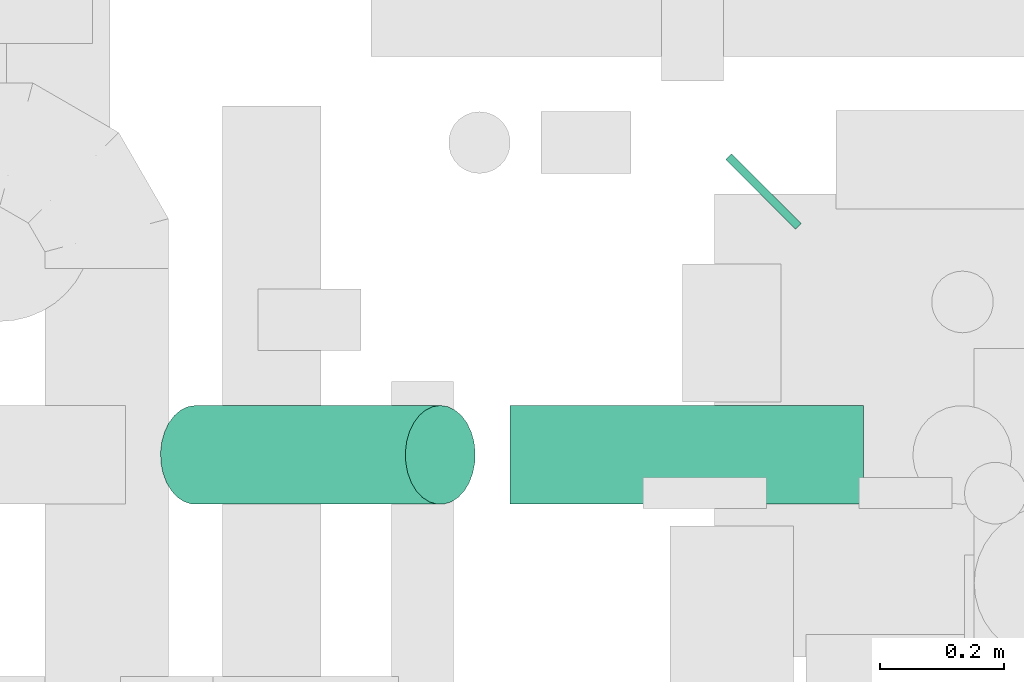
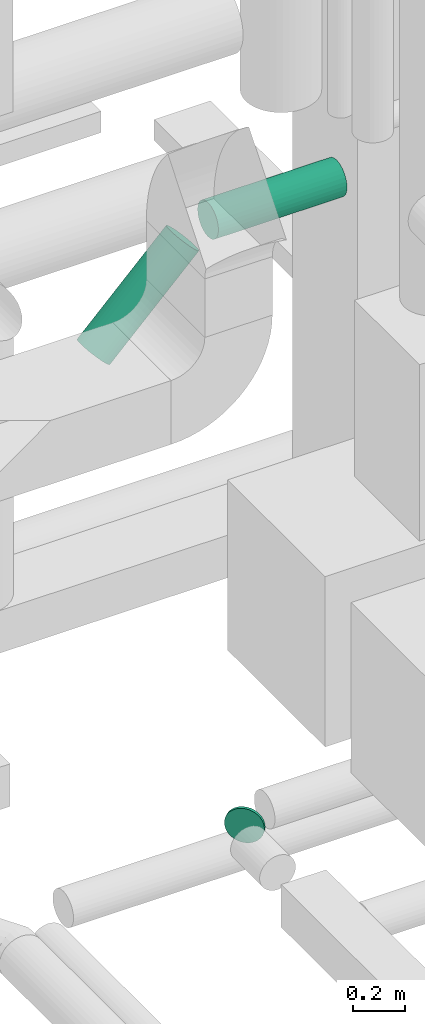
# One storey, part 244 of 337: 3 flow segments.
"""IFC2X3 building model written with IfcOpenShell, lengths in millimetres."""

from ifc_helpers import new_model, entity, si_unit, converted_unit, derived_unit, direction, frame, origin, origin_2d_with_axis, place, context, subcontext, project, spatial, circle, extrude, type_object, element, save


model = new_model("IFC2X3")

# Units and contexts
model_context = context("Model", 3, precision=0.01, world=origin(), true_north=direction((6.12303176911189e-17, 1.0)))
body_context = subcontext(model_context, "Body", "Model", "MODEL_VIEW")
ifc_project = project(units=[si_unit("LENGTHUNIT", "METRE", prefix="MILLI"), si_unit("AREAUNIT", "SQUARE_METRE"), si_unit("VOLUMEUNIT", "CUBIC_METRE"), converted_unit("PLANEANGLEUNIT", "DEGREE", entity("IfcRatioMeasure", 0.0174532925199433), si_unit("PLANEANGLEUNIT", "RADIAN"), dimensions=[0, 0, 0, 0, 0, 0, 0]), si_unit("MASSUNIT", "GRAM", prefix="KILO"), derived_unit("MASSDENSITYUNIT", [(si_unit("MASSUNIT", "GRAM", prefix="KILO"), 1), (si_unit("LENGTHUNIT", "METRE"), -3)]), derived_unit("MOMENTOFINERTIAUNIT", [(si_unit("LENGTHUNIT", "METRE"), 4)]), si_unit("TIMEUNIT", "SECOND"), si_unit("FREQUENCYUNIT", "HERTZ"), si_unit("THERMODYNAMICTEMPERATUREUNIT", "DEGREE_CELSIUS"), derived_unit("THERMALTRANSMITTANCEUNIT", [(si_unit("MASSUNIT", "GRAM", prefix="KILO"), 1), (si_unit("THERMODYNAMICTEMPERATUREUNIT", "KELVIN"), -1), (si_unit("TIMEUNIT", "SECOND"), -3)]), derived_unit("VOLUMETRICFLOWRATEUNIT", [(si_unit("LENGTHUNIT", "METRE"), 3), (si_unit("TIMEUNIT", "SECOND"), -1)]), derived_unit("MASSFLOWRATEUNIT", [(si_unit("MASSUNIT", "GRAM", prefix="KILO"), 1), (si_unit("TIMEUNIT", "SECOND"), -1)]), derived_unit("ROTATIONALFREQUENCYUNIT", [(si_unit("TIMEUNIT", "SECOND"), -1)]), si_unit("ELECTRICCURRENTUNIT", "AMPERE"), si_unit("ELECTRICVOLTAGEUNIT", "VOLT"), si_unit("POWERUNIT", "WATT"), si_unit("FORCEUNIT", "NEWTON", prefix="KILO"), si_unit("ILLUMINANCEUNIT", "LUX"), si_unit("LUMINOUSFLUXUNIT", "LUMEN"), si_unit("LUMINOUSINTENSITYUNIT", "CANDELA"), derived_unit("USERDEFINED", [(si_unit("MASSUNIT", "GRAM", prefix="KILO"), -1), (si_unit("LENGTHUNIT", "METRE"), -2), (si_unit("TIMEUNIT", "SECOND"), 3), (si_unit("LUMINOUSFLUXUNIT", "LUMEN"), 1)]), derived_unit("LINEARVELOCITYUNIT", [(si_unit("LENGTHUNIT", "METRE"), 1), (si_unit("TIMEUNIT", "SECOND"), -1)]), si_unit("PRESSUREUNIT", "PASCAL"), derived_unit("USERDEFINED", [(si_unit("LENGTHUNIT", "METRE"), -2), (si_unit("MASSUNIT", "GRAM", prefix="KILO"), 1), (si_unit("TIMEUNIT", "SECOND"), -2)]), derived_unit("LINEARFORCEUNIT", [(si_unit("MASSUNIT", "GRAM", prefix="KILO"), 1), (si_unit("LENGTHUNIT", "METRE"), 1), (si_unit("TIMEUNIT", "SECOND"), -2), (si_unit("LENGTHUNIT", "METRE"), -1)]), derived_unit("PLANARFORCEUNIT", [(si_unit("MASSUNIT", "GRAM", prefix="KILO"), 1), (si_unit("LENGTHUNIT", "METRE"), 1), (si_unit("TIMEUNIT", "SECOND"), -2), (si_unit("LENGTHUNIT", "METRE"), -2)])], contexts=[model_context])

# Site, building, storey
site_placement = place(None, origin())
site = spatial("IfcSite", under=ifc_project, at=site_placement, CompositionType="ELEMENT")
building_placement = place(site_placement, origin())
building = spatial("IfcBuilding", under=site, at=building_placement, CompositionType="ELEMENT")
storey_placement = place(building_placement, origin())
storey = spatial("IfcBuildingStorey", under=building, at=storey_placement, CompositionType="ELEMENT", Elevation=0.0)

# Flow segments
duct_segment_type = type_object("IfcDuctSegmentType", PredefinedType="NOTDEFINED")
flow_segment_1_placement = place(storey_placement, frame((55066.07, 12222.03, 27468.4)))
element("IfcFlowSegment", 1, at=flow_segment_1_placement, inside=storey, type_object=duct_segment_type, context=body_context, shape_type="SweptSolid", body=[
    extrude(circle(Radius=80.0, at=origin_2d_with_axis()), frame((58.16, 58.16, 81.6), z_axis=(0.707106781186632, 0.707106781186464, 0.0), x_axis=(0.707106781186464, -0.707106781186632, 0.0)), (0.0, 0.0, 1.0), 12.8932188133778),
])
flow_segment_2_placement = place(storey_placement, frame((54718.92, 11776.4, 30713.4)))
element("IfcFlowSegment", 2, at=flow_segment_2_placement, inside=storey, type_object=duct_segment_type, context=body_context, shape_type="SweptSolid", body=[
    extrude(circle(Radius=80.0, at=origin_2d_with_axis()), frame((0.0, 81.6, 81.6), z_axis=(1.0, 0.0, 0.0), x_axis=(0.0, 1.0, 0.0)), (0.0, 0.0, 1.0), 571.785442413998),
])
flow_segment_3_placement = place(storey_placement, frame((54151.35, 11776.4, 30293.7)))
element("IfcFlowSegment", 3, at=flow_segment_3_placement, inside=storey, type_object=duct_segment_type, context=body_context, shape_type="SweptSolid", body=[
    extrude(circle(Radius=80.0, at=origin_2d_with_axis()), frame((58.16, 81.6, 58.16), z_axis=(0.707106781186551, 0.0, 0.707106781186544), x_axis=(0.0, 1.0, 0.0)), (0.0, 0.0, 1.0), 560.416305603448),
])

save(model, "model.ifc")
